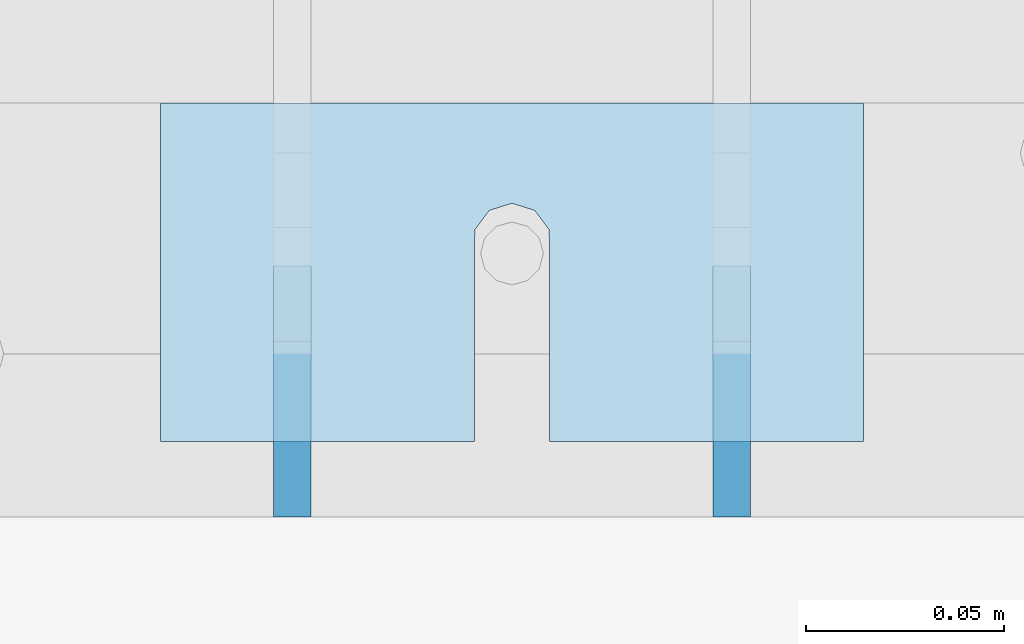
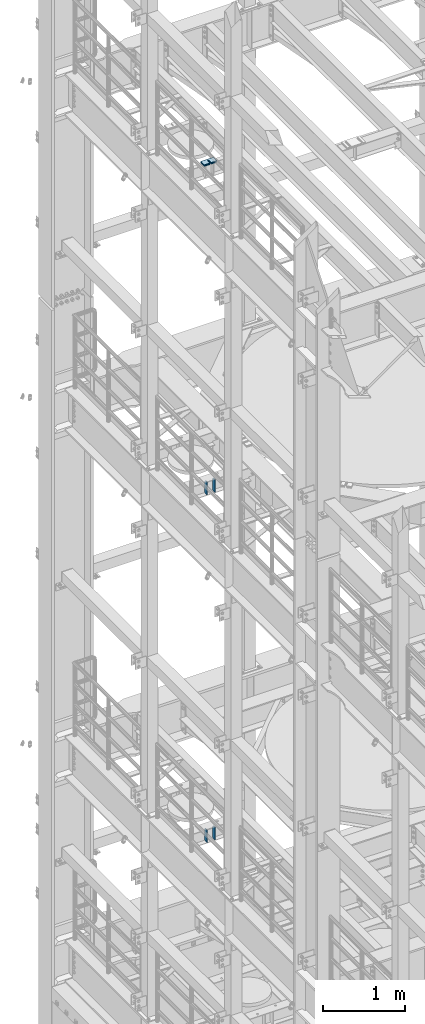
# One storey, part 1745 of 1876: 10 plates, 8 elements without a shape of their own.
"""IFC2X3 building model written with IfcOpenShell, lengths in millimetres."""

from ifc_helpers import new_model, si_unit, frame, origin_with_axes, place, context, subcontext, project, spatial, faceted_brep, material, type_object, element, aggregate, save


model = new_model("IFC2X3")

# Units and contexts
model_context = context("Model", 3, precision=1e-05, world=origin_with_axes())
body_context = subcontext(model_context, "Body", "Model", "MODEL_VIEW")
ifc_project = project(units=[si_unit("LENGTHUNIT", "METRE", prefix="MILLI"), si_unit("AREAUNIT", "SQUARE_METRE"), si_unit("VOLUMEUNIT", "CUBIC_METRE"), si_unit("MASSUNIT", "GRAM", prefix="KILO"), si_unit("TIMEUNIT", "SECOND"), si_unit("PLANEANGLEUNIT", "RADIAN"), si_unit("SOLIDANGLEUNIT", "STERADIAN"), si_unit("THERMODYNAMICTEMPERATUREUNIT", "DEGREE_CELSIUS"), si_unit("LUMINOUSINTENSITYUNIT", "LUMEN")], contexts=[model_context])

# Site, building, storey
site_placement = place(None, origin_with_axes())
site = spatial("IfcSite", under=ifc_project, at=site_placement, CompositionType="ELEMENT")
building_placement = place(site_placement, origin_with_axes())
building = spatial("IfcBuilding", under=site, at=building_placement, Name="Undefined", CompositionType="ELEMENT")
storey_placement = place(building_placement, origin_with_axes())
storey = spatial("IfcBuildingStorey", under=building, at=storey_placement, Name="Undefined", CompositionType="ELEMENT", Elevation=0.0)

# Assembly, plates
assembly_1_placement = place(storey_placement, origin_with_axes())
assembly_1 = element("IfcElementAssembly", 1, at=assembly_1_placement, inside=storey, Name="BEAM", AssemblyPlace="NOTDEFINED", PredefinedType="RIGID_FRAME")
ifc_material = material(Name="STEEL/A36")
plate_type_1 = type_object("IfcPlateType", PredefinedType="NOTDEFINED")
plate_1_placement = place(assembly_1_placement, frame((512.7625, 10975.975, 13111.1625), z_axis=(0.0, 0.0, 1.0), x_axis=(0.0, 1.0, 0.0)))
plate_1 = element("IfcPlate", 2, at=plate_1_placement, type_object=plate_type_1, material=ifc_material, Name="PLATE", context=body_context, shape_type="Brep", body=[
    faceted_brep([(0.0, -4.76249999999982, 0.0), (0.0, -4.76249999999982, 190.5), (0.0, 4.76249999999982, 190.5), (0.0, 4.76249999999982, 0.0), (44.4500007629395, -4.76249999999982, 190.5), (44.4500007629395, 4.76249999999982, 190.5), (63.5, -4.76249999999982, 171.450000762939), (63.5, 4.76249999999982, 171.450000762939), (63.5, -4.76249999999982, 19.0499992370605), (63.5, 4.76249999999982, 19.0499992370605), (44.4500007629395, -4.76249999999982, 0.0), (44.4500007629395, 4.76249999999982, 0.0)], [[[0, 1, 2, 3]], [[1, 4, 5, 2]], [[4, 6, 7, 5]], [[6, 8, 9, 7]], [[8, 10, 11, 9]], [[10, 0, 3, 11]], [[5, 7, 9, 11, 3, 2]], [[10, 8, 6, 4, 1, 0]]]),
])
plate_2_placement = place(assembly_1_placement, frame((401.6375, 10975.975, 13111.1625), z_axis=(0.0, 0.0, 1.0), x_axis=(0.0, 1.0, 0.0)))
plate_2 = element("IfcPlate", 3, at=plate_2_placement, type_object=plate_type_1, material=ifc_material, Name="PLATE", context=body_context, shape_type="Brep", body=[
    faceted_brep([(0.0, -4.76249999999982, 0.0), (0.0, -4.76249999999982, 190.5), (0.0, 4.76249999999982, 190.5), (0.0, 4.76249999999982, 0.0), (44.4500007629395, -4.76249999999982, 190.5), (44.4500007629395, 4.76249999999982, 190.5), (63.5, -4.76249999999982, 171.450000762939), (63.5, 4.76249999999982, 171.450000762939), (63.5, -4.76249999999982, 19.0499992370605), (63.5, 4.76249999999982, 19.0499992370605), (44.4500007629395, -4.76249999999982, 0.0), (44.4500007629395, 4.76249999999982, 0.0)], [[[0, 1, 2, 3]], [[1, 4, 5, 2]], [[4, 6, 7, 5]], [[6, 8, 9, 7]], [[8, 10, 11, 9]], [[10, 0, 3, 11]], [[5, 7, 9, 11, 3, 2]], [[10, 8, 6, 4, 1, 0]]]),
])
aggregate(assembly_1, [plate_1, plate_2])

assembly_2_placement = place(storey_placement, origin_with_axes())
assembly_2 = element("IfcElementAssembly", 4, at=assembly_2_placement, inside=storey, Name="BEAM", AssemblyPlace="NOTDEFINED", PredefinedType="RIGID_FRAME")
plate_3_placement = place(assembly_2_placement, frame((512.762, 10975.975, 7954.9625), z_axis=(0.0, 0.0, 1.0), x_axis=(0.0, 1.0, 0.0)))
plate_3 = element("IfcPlate", 5, at=plate_3_placement, type_object=plate_type_1, material=ifc_material, Name="PLATE", context=body_context, shape_type="Brep", body=[
    faceted_brep([(0.0, -4.76249999999982, 0.0), (0.0, -4.76249999999982, 190.5), (0.0, 4.76249999999982, 190.5), (0.0, 4.76249999999982, 0.0), (44.4500007629395, -4.76249999999982, 190.5), (44.4500007629395, 4.76249999999982, 190.5), (63.5, -4.76249999999982, 171.450000762939), (63.5, 4.76249999999982, 171.450000762939), (63.5, -4.76249999999982, 19.0499992370605), (63.5, 4.76249999999982, 19.0499992370605), (44.4500007629395, -4.76249999999982, 0.0), (44.4500007629395, 4.76249999999982, 0.0)], [[[0, 1, 2, 3]], [[1, 4, 5, 2]], [[4, 6, 7, 5]], [[6, 8, 9, 7]], [[8, 10, 11, 9]], [[10, 0, 3, 11]], [[5, 7, 9, 11, 3, 2]], [[10, 8, 6, 4, 1, 0]]]),
])
plate_4_placement = place(assembly_2_placement, frame((401.6375, 10975.975, 7954.9625), z_axis=(0.0, 0.0, 1.0), x_axis=(0.0, 1.0, 0.0)))
plate_4 = element("IfcPlate", 6, at=plate_4_placement, type_object=plate_type_1, material=ifc_material, Name="PLATE", context=body_context, shape_type="Brep", body=[
    faceted_brep([(0.0, -4.76249999999982, 0.0), (0.0, -4.76249999999982, 190.5), (0.0, 4.76249999999982, 190.5), (0.0, 4.76249999999982, 0.0), (44.4500007629395, -4.76249999999982, 190.5), (44.4500007629395, 4.76249999999982, 190.5), (63.5, -4.76249999999982, 171.450000762939), (63.5, 4.76249999999982, 171.450000762939), (63.5, -4.76249999999982, 19.0499992370605), (63.5, 4.76249999999982, 19.0499992370605), (44.4500007629395, -4.76249999999982, 0.0), (44.4500007629395, 4.76249999999982, 0.0)], [[[0, 1, 2, 3]], [[1, 4, 5, 2]], [[4, 6, 7, 5]], [[6, 8, 9, 7]], [[8, 10, 11, 9]], [[10, 0, 3, 11]], [[5, 7, 9, 11, 3, 2]], [[10, 8, 6, 4, 1, 0]]]),
])
aggregate(assembly_2, [plate_3, plate_4])

# Assembly, plate
assembly_3_placement = place(storey_placement, origin_with_axes())
assembly_3 = element("IfcElementAssembly", 7, at=assembly_3_placement, inside=storey, Name="SHIM PLATE", AssemblyPlace="NOTDEFINED", PredefinedType="RIGID_FRAME")
plate_type_2 = type_object("IfcPlateType", PredefinedType="NOTDEFINED")
plate_5_placement = place(assembly_3_placement, frame((546.102974888169, 11080.749789041, 17987.9625), z_axis=(-1.18599999689195e-06, -0.999999999999297, 0.0), x_axis=(-0.999999999999297, 1.18599999685595e-06, 0.0)))
plate_5 = element("IfcPlate", 8, at=plate_5_placement, type_object=plate_type_2, material=ifc_material, Name="SHIM PLATE", context=body_context, shape_type="Brep", body=[
    faceted_brep([(79.3771379778037, -4.76250000000073, 85.7271118165263), (79.37941579775, -4.76250000000073, 38.1018605431018), (79.37941579775, 4.76250000000073, 38.1018605431018), (79.3771379778037, 4.76250000000073, 85.7271118165263), (79.5321553344801, -4.76250000000073, 32.0673270398438), (79.5321553344801, 4.76250000000073, 32.0673270398438), (83.1540408125562, -4.76250000000073, 27.2381584207487), (83.1540408125562, 4.76250000000073, 27.2381584207487), (88.9044302925666, -4.76250000000073, 25.4018728231113), (88.9044302925666, 4.76250000000073, 25.4018728231113), (94.6548154736501, -4.76250000000073, 27.2381718829492), (94.6548154736501, 4.76250000000073, 27.2381718829492), (98.2766896461945, -4.76250000000073, 32.067348981207), (98.2766896461945, 4.76250000000073, 32.067348981207), (98.429415055534, -4.76250000000073, 38.1018828420274), (98.429415055534, 4.76250000000073, 38.1018828420274), (98.4271372355728, -4.76250000000073, 85.7271231135492), (98.4271372355727, 4.76250000000073, 85.727111816539), (0.0, -4.76249999999982, 0.0), (0.00274557596708291, -4.76250000000073, 85.7271118164699), (0.00274557596708291, 4.76250000000073, 85.7271118164699), (0.0, 4.76249999999982, 0.0), (177.801635742191, -4.76250000000073, 1.21872290037572e-10), (177.801635742191, 4.76250000000073, 1.21872290037572e-10), (177.801528930665, -4.76250000000073, 85.7271118165972), (177.801528930665, 4.76250000000073, 85.7271118165972)], [[[0, 1, 2, 3]], [[4, 5, 2, 1]], [[6, 7, 5, 4]], [[8, 9, 7, 6]], [[10, 11, 9, 8]], [[12, 13, 11, 10]], [[14, 15, 13, 12]], [[16, 17, 15, 14]], [[18, 19, 20, 21]], [[22, 18, 21, 23]], [[24, 22, 23, 25]], [[12, 10, 8, 6, 4, 1, 0, 19, 18, 22, 24, 16, 14]], [[20, 19, 0, 3]], [[25, 23, 21, 20, 3, 2, 5, 7, 9, 11, 13, 15, 17]], [[24, 25, 17, 16]]]),
])
aggregate(assembly_3, [plate_5])

assembly_4_placement = place(storey_placement, origin_with_axes())
assembly_4 = element("IfcElementAssembly", 9, at=assembly_4_placement, inside=storey, Name="SHIM PLATE", AssemblyPlace="NOTDEFINED", PredefinedType="RIGID_FRAME")
plate_type_3 = type_object("IfcPlateType", PredefinedType="NOTDEFINED")
plate_6_placement = place(assembly_4_placement, frame((546.102974888207, 11080.7497890422, 18009.3925), z_axis=(-1.18599999689195e-06, -0.999999999999297, 0.0), x_axis=(-0.999999999999297, 1.18599999685595e-06, 0.0)))
plate_6 = element("IfcPlate", 10, at=plate_6_placement, type_object=plate_type_3, material=ifc_material, Name="SHIM PLATE", context=body_context, shape_type="Brep", body=[
    faceted_brep([(79.3771379778037, -0.793499999999767, 85.7271118165263), (79.37941579775, -0.793499999999767, 38.1018605431018), (79.37941579775, 0.793499999999767, 38.1018605431018), (79.3771379778037, 0.793499999999767, 85.7271118165263), (79.5321553344801, -0.793499999999767, 32.0673270398438), (79.5321553344801, 0.793499999999767, 32.0673270398438), (83.1540408125562, -0.793499999999767, 27.2381584207487), (83.1540408125562, 0.793499999999767, 27.2381584207487), (88.9044302925666, -0.793499999999767, 25.4018728231113), (88.9044302925666, 0.793499999999767, 25.4018728231113), (94.6548154736501, -0.793499999999767, 27.2381718829492), (94.6548154736501, 0.793499999999767, 27.2381718829492), (98.2766896461945, -0.793499999999767, 32.067348981207), (98.2766896461945, 0.793499999999767, 32.067348981207), (98.429415055534, -0.793499999999767, 38.1018828420274), (98.429415055534, 0.793499999999767, 38.1018828420274), (98.4271372355728, -0.793499999999767, 85.7271231135492), (98.4271372355727, 0.793499999999767, 85.727111816539), (9.09494701772928e-13, -0.793499999999767, 0.0), (0.00274557596708291, -0.793499999999767, 85.7271118164699), (0.00274557596708291, 0.793499999999767, 85.7271118164699), (9.09494701772928e-13, 0.793499999999767, 0.0), (177.801635742191, -0.793499999999767, 1.36424205265939e-10), (177.801635742191, 0.793499999999767, 1.36424205265939e-10), (177.801528930665, -0.793499999999767, 85.7271118165972), (177.801528930665, 0.793499999999767, 85.7271118165972)], [[[0, 1, 2, 3]], [[4, 5, 2, 1]], [[6, 7, 5, 4]], [[8, 9, 7, 6]], [[10, 11, 9, 8]], [[12, 13, 11, 10]], [[14, 15, 13, 12]], [[16, 17, 15, 14]], [[18, 19, 20, 21]], [[22, 18, 21, 23]], [[24, 22, 23, 25]], [[12, 10, 8, 6, 4, 1, 0, 19, 18, 22, 24, 16, 14]], [[20, 19, 0, 3]], [[25, 23, 21, 20, 3, 2, 5, 7, 9, 11, 13, 15, 17]], [[24, 25, 17, 16]]]),
])
aggregate(assembly_4, [plate_6])

assembly_5_placement = place(storey_placement, origin_with_axes())
assembly_5 = element("IfcElementAssembly", 11, at=assembly_5_placement, inside=storey, Name="SHIM PLATE", AssemblyPlace="NOTDEFINED", PredefinedType="RIGID_FRAME")
plate_type_4 = type_object("IfcPlateType", PredefinedType="NOTDEFINED")
plate_7_placement = place(assembly_5_placement, frame((546.102974888199, 11080.749789042, 18007.0115), z_axis=(-1.18599999689195e-06, -0.999999999999297, 0.0), x_axis=(-0.999999999999297, 1.18599999685595e-06, 0.0)))
plate_7 = element("IfcPlate", 12, at=plate_7_placement, type_object=plate_type_4, material=ifc_material, Name="SHIM PLATE", context=body_context, shape_type="Brep", body=[
    faceted_brep([(79.3771379778037, -1.58750000000146, 85.7271118165263), (79.37941579775, -1.58750000000146, 38.1018605431018), (79.37941579775, 1.58750000000146, 38.1018605431018), (79.3771379778037, 1.58750000000146, 85.7271118165263), (79.5321553344801, -1.58750000000146, 32.0673270398438), (79.5321553344801, 1.58750000000146, 32.0673270398438), (83.1540408125562, -1.58750000000146, 27.2381584207487), (83.1540408125562, 1.58750000000146, 27.2381584207487), (88.9044302925666, -1.58750000000146, 25.4018728231113), (88.9044302925666, 1.58750000000146, 25.4018728231113), (94.6548154736501, -1.58750000000146, 27.2381718829492), (94.6548154736501, 1.58750000000146, 27.2381718829492), (98.2766896461945, -1.58750000000146, 32.067348981207), (98.2766896461945, 1.58750000000146, 32.067348981207), (98.429415055534, -1.58750000000146, 38.1018828420274), (98.429415055534, 1.58750000000146, 38.1018828420274), (98.4271372355728, -1.58750000000146, 85.7271231135492), (98.4271372355727, 1.58750000000146, 85.727111816539), (9.09494701772928e-13, -1.58750000000146, 4.54747350886464e-13), (0.00274557596708291, -1.58750000000146, 85.7271118164699), (0.00274557596708291, 1.58750000000146, 85.7271118164699), (9.09494701772928e-13, 1.58750000000146, 4.54747350886464e-13), (177.801635742191, -1.58750000000146, 1.38243194669485e-10), (177.801635742191, 1.58750000000146, 1.38243194669485e-10), (177.801528930665, -1.58750000000146, 85.7271118165972), (177.801528930665, 1.58750000000146, 85.7271118165972)], [[[0, 1, 2, 3]], [[4, 5, 2, 1]], [[6, 7, 5, 4]], [[8, 9, 7, 6]], [[10, 11, 9, 8]], [[12, 13, 11, 10]], [[14, 15, 13, 12]], [[16, 17, 15, 14]], [[18, 19, 20, 21]], [[22, 18, 21, 23]], [[24, 22, 23, 25]], [[12, 10, 8, 6, 4, 1, 0, 19, 18, 22, 24, 16, 14]], [[20, 19, 0, 3]], [[25, 23, 21, 20, 3, 2, 5, 7, 9, 11, 13, 15, 17]], [[24, 25, 17, 16]]]),
])
aggregate(assembly_5, [plate_7])

assembly_6_placement = place(storey_placement, origin_with_axes())
assembly_6 = element("IfcElementAssembly", 13, at=assembly_6_placement, inside=storey, Name="SHIM PLATE", AssemblyPlace="NOTDEFINED", PredefinedType="RIGID_FRAME")
plate_8_placement = place(assembly_6_placement, frame((546.102974888193, 11080.7497890418, 18003.8365), z_axis=(-1.18599999689195e-06, -0.999999999999297, 0.0), x_axis=(-0.999999999999297, 1.18599999685595e-06, 0.0)))
plate_8 = element("IfcPlate", 14, at=plate_8_placement, type_object=plate_type_4, material=ifc_material, Name="SHIM PLATE", context=body_context, shape_type="Brep", body=[
    faceted_brep([(79.3771379778037, -1.58750000000146, 85.7271118165263), (79.37941579775, -1.58750000000146, 38.1018605431018), (79.37941579775, 1.58750000000146, 38.1018605431018), (79.3771379778037, 1.58750000000146, 85.7271118165263), (79.5321553344801, -1.58750000000146, 32.0673270398438), (79.5321553344801, 1.58750000000146, 32.0673270398438), (83.1540408125562, -1.58750000000146, 27.2381584207487), (83.1540408125562, 1.58750000000146, 27.2381584207487), (88.9044302925666, -1.58750000000146, 25.4018728231113), (88.9044302925666, 1.58750000000146, 25.4018728231113), (94.6548154736501, -1.58750000000146, 27.2381718829492), (94.6548154736501, 1.58750000000146, 27.2381718829492), (98.2766896461945, -1.58750000000146, 32.067348981207), (98.2766896461945, 1.58750000000146, 32.067348981207), (98.429415055534, -1.58750000000146, 38.1018828420274), (98.429415055534, 1.58750000000146, 38.1018828420274), (98.4271372355728, -1.58750000000146, 85.7271231135492), (98.4271372355727, 1.58750000000146, 85.727111816539), (9.09494701772928e-13, -1.58750000000146, 4.54747350886464e-13), (0.00274557596708291, -1.58750000000146, 85.7271118164699), (0.00274557596708291, 1.58750000000146, 85.7271118164699), (9.09494701772928e-13, 1.58750000000146, 4.54747350886464e-13), (177.801635742191, -1.58750000000146, 1.38243194669485e-10), (177.801635742191, 1.58750000000146, 1.38243194669485e-10), (177.801528930665, -1.58750000000146, 85.7271118165972), (177.801528930665, 1.58750000000146, 85.7271118165972)], [[[0, 1, 2, 3]], [[4, 5, 2, 1]], [[6, 7, 5, 4]], [[8, 9, 7, 6]], [[10, 11, 9, 8]], [[12, 13, 11, 10]], [[14, 15, 13, 12]], [[16, 17, 15, 14]], [[18, 19, 20, 21]], [[22, 18, 21, 23]], [[24, 22, 23, 25]], [[12, 10, 8, 6, 4, 1, 0, 19, 18, 22, 24, 16, 14]], [[20, 19, 0, 3]], [[25, 23, 21, 20, 3, 2, 5, 7, 9, 11, 13, 15, 17]], [[24, 25, 17, 16]]]),
])
aggregate(assembly_6, [plate_8])

assembly_7_placement = place(storey_placement, origin_with_axes())
assembly_7 = element("IfcElementAssembly", 15, at=assembly_7_placement, inside=storey, Name="SHIM PLATE", AssemblyPlace="NOTDEFINED", PredefinedType="RIGID_FRAME")
plate_type_5 = type_object("IfcPlateType", PredefinedType="NOTDEFINED")
plate_9_placement = place(assembly_7_placement, frame((546.102974888188, 11080.7497890415, 17999.868), z_axis=(-1.18599999689195e-06, -0.999999999999297, 0.0), x_axis=(-0.999999999999297, 1.18599999685595e-06, 0.0)))
plate_9 = element("IfcPlate", 16, at=plate_9_placement, type_object=plate_type_5, material=ifc_material, Name="SHIM PLATE", context=body_context, shape_type="Brep", body=[
    faceted_brep([(79.3771379778037, -2.38100000000122, 85.7271118165263), (79.37941579775, -2.38100000000122, 38.1018605431018), (79.37941579775, 2.38100000000122, 38.1018605431018), (79.3771379778037, 2.38100000000122, 85.7271118165263), (79.5321553344801, -2.38100000000122, 32.0673270398438), (79.5321553344801, 2.38100000000122, 32.0673270398438), (83.1540408125562, -2.38100000000122, 27.2381584207487), (83.1540408125562, 2.38100000000122, 27.2381584207487), (88.9044302925666, -2.38100000000122, 25.4018728231113), (88.9044302925666, 2.38100000000122, 25.4018728231113), (94.6548154736501, -2.38100000000122, 27.2381718829492), (94.6548154736501, 2.38100000000122, 27.2381718829492), (98.2766896461945, -2.38100000000122, 32.067348981207), (98.2766896461945, 2.38100000000122, 32.067348981207), (98.429415055534, -2.38100000000122, 38.1018828420274), (98.429415055534, 2.38100000000122, 38.1018828420274), (98.4271372355728, -2.38100000000122, 85.7271231135492), (98.4271372355727, 2.38100000000122, 85.727111816539), (0.0, -2.38100000000122, 4.54747350886464e-13), (0.00274557596708291, -2.38100000000122, 85.7271118164699), (0.00274557596708291, 2.38100000000122, 85.7271118164699), (0.0, 2.38100000000122, 4.54747350886464e-13), (177.801635742191, -2.38100000000122, 1.20053300634027e-10), (177.801635742191, 2.38100000000122, 1.20053300634027e-10), (177.801528930665, -2.38100000000122, 85.7271118165972), (177.801528930665, 2.38100000000122, 85.7271118165972)], [[[0, 1, 2, 3]], [[4, 5, 2, 1]], [[6, 7, 5, 4]], [[8, 9, 7, 6]], [[10, 11, 9, 8]], [[12, 13, 11, 10]], [[14, 15, 13, 12]], [[16, 17, 15, 14]], [[18, 19, 20, 21]], [[22, 18, 21, 23]], [[24, 22, 23, 25]], [[12, 10, 8, 6, 4, 1, 0, 19, 18, 22, 24, 16, 14]], [[20, 19, 0, 3]], [[25, 23, 21, 20, 3, 2, 5, 7, 9, 11, 13, 15, 17]], [[24, 25, 17, 16]]]),
])
aggregate(assembly_7, [plate_9])

assembly_8_placement = place(storey_placement, origin_with_axes())
assembly_8 = element("IfcElementAssembly", 17, at=assembly_8_placement, inside=storey, Name="SHIM PLATE", AssemblyPlace="NOTDEFINED", PredefinedType="RIGID_FRAME")
plate_10_placement = place(assembly_8_placement, frame((546.102974888179, 11080.7497890413, 17995.106), z_axis=(-1.18599999689195e-06, -0.999999999999297, 0.0), x_axis=(-0.999999999999297, 1.18599999685595e-06, 0.0)))
plate_10 = element("IfcPlate", 18, at=plate_10_placement, type_object=plate_type_5, material=ifc_material, Name="SHIM PLATE", context=body_context, shape_type="Brep", body=[
    faceted_brep([(79.3771379778037, -2.38100000000122, 85.7271118165263), (79.37941579775, -2.38100000000122, 38.1018605431018), (79.37941579775, 2.38100000000122, 38.1018605431018), (79.3771379778037, 2.38100000000122, 85.7271118165263), (79.5321553344801, -2.38100000000122, 32.0673270398438), (79.5321553344801, 2.38100000000122, 32.0673270398438), (83.1540408125562, -2.38100000000122, 27.2381584207487), (83.1540408125562, 2.38100000000122, 27.2381584207487), (88.9044302925666, -2.38100000000122, 25.4018728231113), (88.9044302925666, 2.38100000000122, 25.4018728231113), (94.6548154736501, -2.38100000000122, 27.2381718829492), (94.6548154736501, 2.38100000000122, 27.2381718829492), (98.2766896461945, -2.38100000000122, 32.067348981207), (98.2766896461945, 2.38100000000122, 32.067348981207), (98.429415055534, -2.38100000000122, 38.1018828420274), (98.429415055534, 2.38100000000122, 38.1018828420274), (98.4271372355728, -2.38100000000122, 85.7271231135492), (98.4271372355727, 2.38100000000122, 85.727111816539), (0.0, -2.38100000000122, 4.54747350886464e-13), (0.00274557596708291, -2.38100000000122, 85.7271118164699), (0.00274557596708291, 2.38100000000122, 85.7271118164699), (0.0, 2.38100000000122, 4.54747350886464e-13), (177.801635742191, -2.38100000000122, 1.20053300634027e-10), (177.801635742191, 2.38100000000122, 1.20053300634027e-10), (177.801528930665, -2.38100000000122, 85.7271118165972), (177.801528930665, 2.38100000000122, 85.7271118165972)], [[[0, 1, 2, 3]], [[4, 5, 2, 1]], [[6, 7, 5, 4]], [[8, 9, 7, 6]], [[10, 11, 9, 8]], [[12, 13, 11, 10]], [[14, 15, 13, 12]], [[16, 17, 15, 14]], [[18, 19, 20, 21]], [[22, 18, 21, 23]], [[24, 22, 23, 25]], [[12, 10, 8, 6, 4, 1, 0, 19, 18, 22, 24, 16, 14]], [[20, 19, 0, 3]], [[25, 23, 21, 20, 3, 2, 5, 7, 9, 11, 13, 15, 17]], [[24, 25, 17, 16]]]),
])
aggregate(assembly_8, [plate_10])

save(model, "model.ifc")
